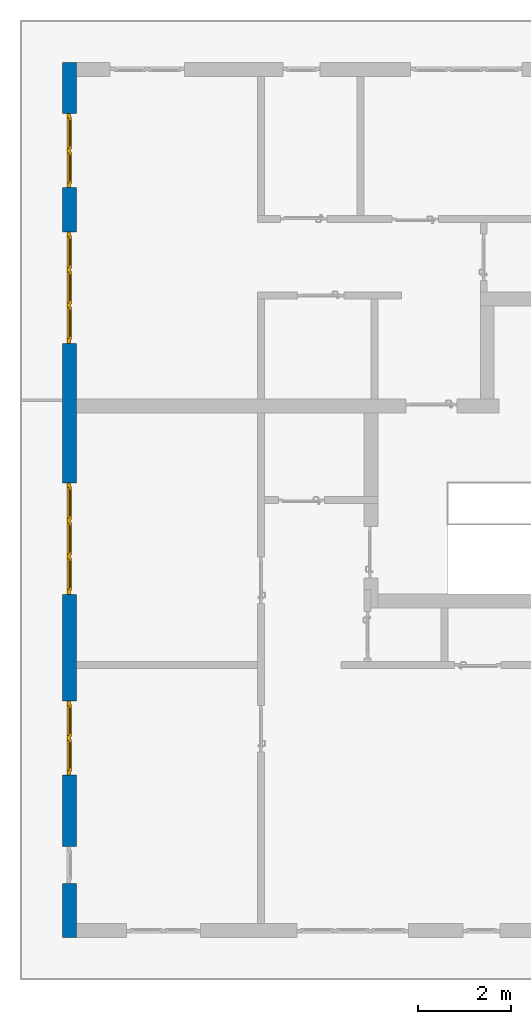
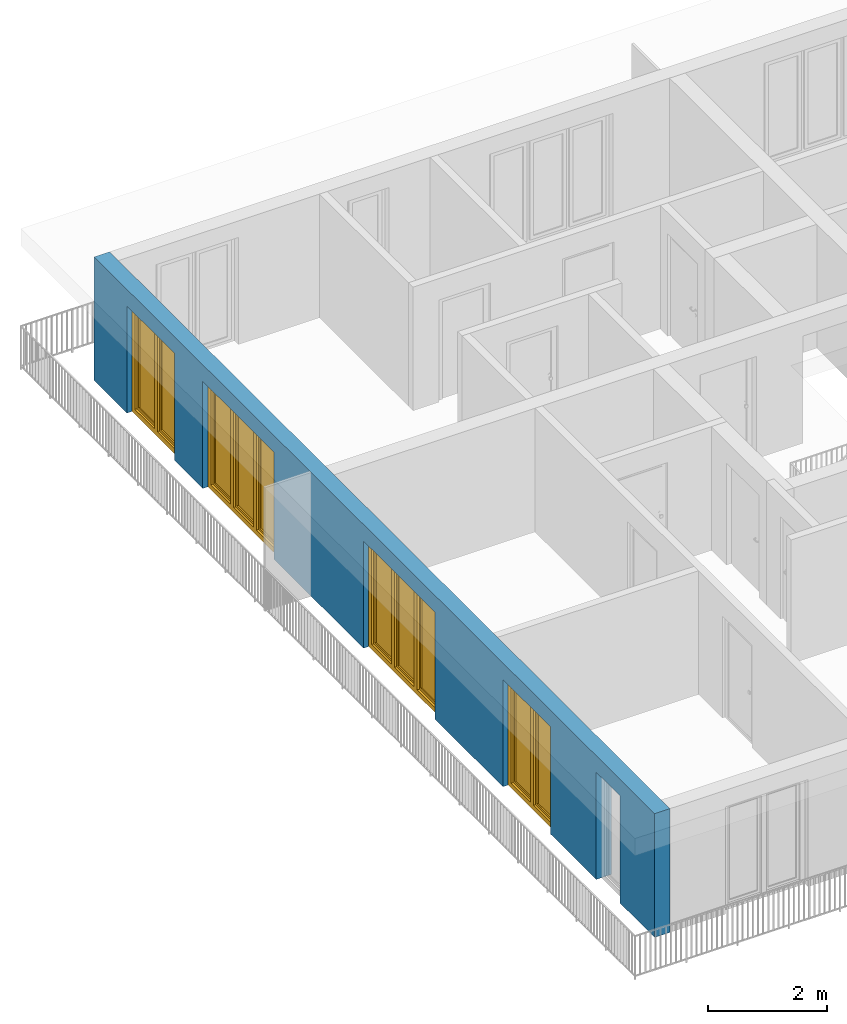
# One storey, part 11 of 54: 4 windows, 1 wall, 5 openings.
"""IFC4 building model written with IfcOpenShell, lengths in metres."""

from ifc_helpers import new_model, entity, si_unit, converted_unit, derived_unit, direction, frame, origin_with_axes, place, context, subcontext, project, spatial, polygons, source, transform, mapped, material, type_object, element, fill, save


model = new_model("IFC4")

# Units and contexts
model_context = context("Model", 3, precision=1e-05, world=origin_with_axes(), true_north=direction((0.0, 1.0)))
body_context = subcontext(model_context, "Body", "Model", "MODEL_VIEW")
ifc_project = project(units=[si_unit("LENGTHUNIT", "METRE"), si_unit("AREAUNIT", "SQUARE_METRE"), si_unit("VOLUMEUNIT", "CUBIC_METRE"), converted_unit("PLANEANGLEUNIT", "DEGREE", entity("IfcPlaneAngleMeasure", 0.0174532925199), si_unit("PLANEANGLEUNIT", "RADIAN"), dimensions=[0, 0, 0, 0, 0, 0, 0]), converted_unit("TIMEUNIT", "Year", entity("IfcTimeMeasure", 31556926.0), si_unit("TIMEUNIT", "SECOND"), dimensions=[0, 0, 1, 0, 0, 0, 0]), si_unit("MASSUNIT", "GRAM", prefix="KILO"), si_unit("THERMODYNAMICTEMPERATUREUNIT", "DEGREE_CELSIUS"), si_unit("LUMINOUSINTENSITYUNIT", "LUMEN"), si_unit("ENERGYUNIT", "JOULE", prefix="MEGA"), derived_unit("THERMALCONDUCTANCEUNIT", [(si_unit("POWERUNIT", "WATT"), 1), (si_unit("LENGTHUNIT", "METRE"), -1), (si_unit("THERMODYNAMICTEMPERATUREUNIT", "KELVIN"), -1)]), derived_unit("SPECIFICHEATCAPACITYUNIT", [(si_unit("ENERGYUNIT", "JOULE"), 1), (si_unit("MASSUNIT", "GRAM", prefix="KILO"), -1), (si_unit("THERMODYNAMICTEMPERATUREUNIT", "KELVIN"), -1)]), derived_unit("MASSDENSITYUNIT", [(si_unit("MASSUNIT", "GRAM", prefix="KILO"), 1), (si_unit("VOLUMEUNIT", "CUBIC_METRE"), -1)])], contexts=[model_context])

# Site, building, storey
site_placement = place(None, origin_with_axes())
site = spatial("IfcSite", under=ifc_project, at=site_placement, CompositionType="ELEMENT")
building_placement = place(site_placement, origin_with_axes())
building = spatial("IfcBuilding", under=site, at=building_placement, CompositionType="ELEMENT")
storey_placement = place(building_placement, frame((0.0, 0.0, 6.29), z_axis=(0.0, 0.0, 1.0), x_axis=(1.0, 0.0, 0.0)))
storey = spatial("IfcBuildingStorey", under=building, at=storey_placement, Name="2. Geschoss", CompositionType="ELEMENT", Elevation=6.29)

# Wall, openings, windows
ifc_material = material()
wall_type = type_object("IfcWallType", Name="300", PredefinedType="NOTDEFINED")
wall_placement = place(storey_placement, frame((-11.7421993804, -9.92881223104, 0.0), z_axis=(0.0, 0.0, 1.0), x_axis=(0.0, 1.0, 0.0)))
wall = element("IfcWall", 1, at=wall_placement, inside=storey, type_object=wall_type, material=ifc_material, Name="Wand-001", PredefinedType="NOTDEFINED", context=body_context, shape_type="Tessellation", body=[
    polygons([(1.16441876325, -0.3, 0.0), (1.16441876325, -0.3, 2.2), (1.96441876325, -0.3, 2.2), (1.96441876325, -0.3, 0.0), (3.5, -0.3, 0.0), (3.5, -0.3, 2.2), (5.1, -0.3, 2.2), (5.1, -0.3, 0.0), (7.3921181063, -0.3, 0.0), (7.3921181063, -0.3, 2.2), (9.7921181063, -0.3, 2.2), (9.7921181063, -0.3, 0.0), (12.8, -0.3, 0.0), (12.8, -0.3, 2.2), (15.2, -0.3, 2.2), (15.2, -0.3, 0.0), (16.15, -0.3, 0.0), (16.15, -0.3, 2.2), (17.75, -0.3, 2.2), (17.75, -0.3, 0.0), (18.85, -0.3, 0.0), (18.85, -0.3, 2.54), (0.0, -0.3, 2.54), (0.0, -0.3, 0.0), (1.16441876325, -0.1, 0.0), (1.16441876325, -0.1, 2.2), (1.96441876325, -0.1, 2.2), (1.96441876325, -0.1, 0.0), (1.96441876325, 0.0, 0.0), (3.5, 0.0, 0.0), (3.5, -0.1, 0.0), (3.5, -0.1, 2.2), (5.1, -0.1, 2.2), (5.1, -0.1, 0.0), (5.1, 0.0, 0.0), (7.3921181063, 0.0, 0.0), (7.3921181063, -0.1, 0.0), (7.3921181063, -0.1, 2.2), (9.7921181063, -0.1, 2.2), (9.7921181063, -0.1, 0.0), (9.7921181063, 0.0, 0.0), (12.8, 0.0, 0.0), (12.8, -0.1, 0.0), (12.8, -0.1, 2.2), (15.2, -0.1, 2.2), (15.2, -0.1, 0.0), (15.2, 0.0, 0.0), (16.15, 0.0, 0.0), (16.15, -0.1, 0.0), (16.15, -0.1, 2.2), (17.75, -0.1, 2.2), (17.75, -0.1, 0.0), (17.75, 0.0, 0.0), (18.85, 0.0, 0.0), (18.85, 0.0, 2.54), (0.0, 0.0, 2.54), (0.0, 0.0, 0.0), (1.16441876325, 0.0, 0.0), (1.16441876325, 0.0, 2.2), (1.96441876325, 0.0, 2.2), (17.75, 0.0, 2.2), (16.15, 0.0, 2.2), (15.2, 0.0, 2.2), (12.8, 0.0, 2.2), (9.7921181063, 0.0, 2.2), (7.3921181063, 0.0, 2.2), (5.1, 0.0, 2.2), (3.5, 0.0, 2.2)], [[[1, 2, 3, 4, 5, 6, 7, 8, 9, 10, 11, 12, 13, 14, 15, 16, 17, 18, 19, 20, 21, 22, 23, 24]], [[2, 1, 25, 26]], [[3, 2, 26, 27]], [[4, 3, 27, 28]], [[4, 28, 29, 30, 31, 5]], [[31, 32, 6, 5]], [[32, 33, 7, 6]], [[33, 34, 8, 7]], [[8, 34, 35, 36, 37, 9]], [[10, 9, 37, 38]], [[11, 10, 38, 39]], [[12, 11, 39, 40]], [[12, 40, 41, 42, 43, 13]], [[43, 44, 14, 13]], [[44, 45, 15, 14]], [[45, 46, 16, 15]], [[16, 46, 47, 48, 49, 17]], [[18, 17, 49, 50]], [[19, 18, 50, 51]], [[20, 19, 51, 52]], [[52, 53, 54, 21, 20]], [[22, 21, 54, 55]], [[22, 55, 56, 23]], [[56, 57, 24, 23]], [[25, 1, 24, 57, 58]], [[26, 25, 58, 59]], [[27, 26, 59, 60]], [[28, 27, 60, 29]], [[30, 29, 60, 59, 58, 57, 56, 55, 54, 53, 61, 62, 48, 47, 63, 64, 42, 41, 65, 66, 36, 35, 67, 68]], [[30, 68, 32, 31]], [[68, 67, 33, 32]], [[67, 35, 34, 33]], [[38, 37, 36, 66]], [[39, 38, 66, 65]], [[40, 39, 65, 41]], [[42, 64, 44, 43]], [[64, 63, 45, 44]], [[63, 47, 46, 45]], [[50, 49, 48, 62]], [[51, 50, 62, 61]], [[52, 51, 61, 53]]], closed=True),
])
opening_1_placement = place(wall_placement, frame((16.95, 0.0, 0.0), z_axis=(0.0, 0.0, 1.0), x_axis=(1.0, 0.0, 0.0)))
opening_1 = element("IfcOpeningElement", 2, at=opening_1_placement, cuts=wall, Name="Fenster-001", context=body_context, identifier="Reference", shape_type="Tessellation", body=[
    polygons([(-0.8, -0.1, 0.0), (-0.8, -0.1, 2.2), (-0.8, 0.000999999999999, 2.2), (-0.8, 0.000999999999999, 0.0), (-0.8, -0.301, 0.0), (-0.8, -0.301, 2.2), (0.8, -0.1, 2.2), (0.8, 0.000999999999999, 2.2), (0.8, -0.301, 2.2), (0.8, 0.000999999999999, 0.0), (0.8, -0.1, 0.0), (0.8, -0.301, 0.0)], [[[1, 2, 3, 4]], [[2, 1, 5, 6]], [[7, 8, 3, 2, 6, 9]], [[8, 10, 4, 3]], [[1, 4, 10, 11, 12, 5]], [[6, 5, 12, 9]], [[7, 11, 10, 8]], [[11, 7, 9, 12]]], closed=True),
])
opening_2_placement = place(wall_placement, frame((14.0, 0.0, 0.0), z_axis=(0.0, 0.0, 1.0), x_axis=(1.0, 0.0, 0.0)))
opening_2 = element("IfcOpeningElement", 3, at=opening_2_placement, cuts=wall, Name="Fenster-002", context=body_context, identifier="Reference", shape_type="Tessellation", body=[
    polygons([(-1.2, -0.1, 0.0), (-1.2, -0.1, 2.2), (-1.2, 0.000999999999999, 2.2), (-1.2, 0.000999999999999, 0.0), (-1.2, -0.301, 0.0), (-1.2, -0.301, 2.2), (1.2, -0.1, 2.2), (1.2, 0.000999999999999, 2.2), (1.2, -0.301, 2.2), (1.2, 0.000999999999999, 0.0), (1.2, -0.1, 0.0), (1.2, -0.301, 0.0)], [[[1, 2, 3, 4]], [[2, 1, 5, 6]], [[7, 8, 3, 2, 6, 9]], [[8, 10, 4, 3]], [[1, 4, 10, 11, 12, 5]], [[6, 5, 12, 9]], [[7, 11, 10, 8]], [[11, 7, 9, 12]]], closed=True),
])
opening_3_placement = place(wall_placement, frame((8.5921181063, 0.0, 0.0), z_axis=(0.0, 0.0, 1.0), x_axis=(1.0, 0.0, 0.0)))
opening_3 = element("IfcOpeningElement", 4, at=opening_3_placement, cuts=wall, Name="Fenster-002", context=body_context, identifier="Reference", shape_type="Tessellation", body=[
    polygons([(-1.2, -0.1, 0.0), (-1.2, -0.1, 2.2), (-1.2, 0.000999999999999, 2.2), (-1.2, 0.000999999999999, 0.0), (-1.2, -0.301, 0.0), (-1.2, -0.301, 2.2), (1.2, -0.1, 2.2), (1.2, 0.000999999999999, 2.2), (1.2, -0.301, 2.2), (1.2, 0.000999999999999, 0.0), (1.2, -0.1, 0.0), (1.2, -0.301, 0.0)], [[[1, 2, 3, 4]], [[2, 1, 5, 6]], [[7, 8, 3, 2, 6, 9]], [[8, 10, 4, 3]], [[1, 4, 10, 11, 12, 5]], [[6, 5, 12, 9]], [[7, 11, 10, 8]], [[11, 7, 9, 12]]], closed=True),
])
opening_4_placement = place(wall_placement, frame((4.3, 0.0, 0.0), z_axis=(0.0, 0.0, 1.0), x_axis=(1.0, 0.0, 0.0)))
opening_4 = element("IfcOpeningElement", 5, at=opening_4_placement, cuts=wall, Name="Fenster-001", context=body_context, identifier="Reference", shape_type="Tessellation", body=[
    polygons([(-0.8, -0.1, 0.0), (-0.8, -0.1, 2.2), (-0.8, 0.000999999999999, 2.2), (-0.8, 0.000999999999999, 0.0), (-0.8, -0.301, 0.0), (-0.8, -0.301, 2.2), (0.8, -0.1, 2.2), (0.8, 0.000999999999999, 2.2), (0.8, -0.301, 2.2), (0.8, 0.000999999999999, 0.0), (0.8, -0.1, 0.0), (0.8, -0.301, 0.0)], [[[1, 2, 3, 4]], [[2, 1, 5, 6]], [[7, 8, 3, 2, 6, 9]], [[8, 10, 4, 3]], [[1, 4, 10, 11, 12, 5]], [[6, 5, 12, 9]], [[7, 11, 10, 8]], [[11, 7, 9, 12]]], closed=True),
])
opening_5_placement = place(wall_placement, frame((1.56441876325, 0.0, 0.0), z_axis=(0.0, 0.0, 1.0), x_axis=(1.0, 0.0, 0.0)))
element("IfcOpeningElement", 6, at=opening_5_placement, cuts=wall, Name="Fenster-003", context=body_context, identifier="Reference", shape_type="Tessellation", body=[
    polygons([(-0.4, -0.1, 0.0), (-0.4, -0.1, 2.2), (-0.4, 0.000999999999999, 2.2), (-0.4, 0.000999999999999, 0.0), (-0.4, -0.301, 0.0), (-0.4, -0.301, 2.2), (0.4, -0.1, 2.2), (0.4, 0.000999999999999, 2.2), (0.4, -0.301, 2.2), (0.4, 0.000999999999999, 0.0), (0.4, -0.1, 0.0), (0.4, -0.301, 0.0)], [[[1, 2, 3, 4]], [[2, 1, 5, 6]], [[7, 8, 3, 2, 6, 9]], [[8, 10, 4, 3]], [[1, 4, 10, 11, 12, 5]], [[6, 5, 12, 9]], [[7, 11, 10, 8]], [[11, 7, 9, 12]]], closed=True),
])
window_type_1 = type_object("IfcWindowType", Name="2-1+1 26", PartitioningType="DOUBLE_PANEL_VERTICAL", PredefinedType="WINDOW")
shared_shape_1 = source(origin_with_axes(), body_context, "Body", "Tessellation", [
    polygons([(0.8, -0.07, 0.0), (0.7, -0.07, 0.1), (0.7, 0.0, 0.1), (0.8, 0.0, 0.0), (0.8, -0.07, 2.2), (0.7, -0.07, 2.1), (0.7, 0.0, 2.1), (0.8, 0.0, 2.2)], [[[1, 2, 3, 4]], [[1, 5, 6, 2]], [[2, 6, 7, 3]], [[4, 3, 7, 8]], [[5, 1, 4, 8]], [[6, 5, 8, 7]]], closed=True),
    polygons([(-0.8, -0.07, 0.0), (-0.8, -0.07, 2.2), (-0.8, 0.0, 2.2), (-0.8, 0.0, 0.0), (-0.7, -0.07, 0.1), (-0.7, -0.07, 2.1), (-0.7, 0.0, 2.1), (-0.7, 0.0, 0.1)], [[[1, 2, 3, 4]], [[1, 5, 6, 2]], [[2, 6, 7, 3]], [[4, 3, 7, 8]], [[5, 1, 4, 8]], [[6, 5, 8, 7]]], closed=True),
    polygons([(0.8, -0.07, 0.0), (-0.8, -0.07, 0.0), (-0.8, 0.0, 0.0), (0.8, 0.0, 0.0), (0.7, -0.07, 0.1), (0.05, -0.07, 0.1), (-0.05, -0.07, 0.1), (-0.7, -0.07, 0.1), (-0.7, 0.0, 0.1), (-0.05, 0.0, 0.1), (0.05, 0.0, 0.1), (0.7, 0.0, 0.1)], [[[1, 2, 3, 4]], [[1, 5, 6, 7, 8, 2]], [[2, 8, 9, 3]], [[4, 3, 9, 10, 11, 12]], [[5, 1, 4, 12]], [[6, 5, 12, 11]], [[7, 6, 11, 10]], [[8, 7, 10, 9]]], closed=True),
    polygons([(0.8, -0.07, 2.2), (0.7, -0.07, 2.1), (0.7, 0.0, 2.1), (0.8, 0.0, 2.2), (-0.8, -0.07, 2.2), (-0.7, -0.07, 2.1), (-0.05, -0.07, 2.1), (0.05, -0.07, 2.1), (0.05, 0.0, 2.1), (-0.05, 0.0, 2.1), (-0.7, 0.0, 2.1), (-0.8, 0.0, 2.2)], [[[1, 2, 3, 4]], [[1, 5, 6, 7, 8, 2]], [[2, 8, 9, 3]], [[4, 3, 9, 10, 11, 12]], [[5, 1, 4, 12]], [[6, 5, 12, 11]], [[7, 6, 11, 10]], [[8, 7, 10, 9]]], closed=True),
    polygons([(0.05, -0.07, 0.1), (-0.05, -0.07, 0.1), (-0.05, 0.0, 0.1), (0.05, 0.0, 0.1), (0.05, -0.07, 2.1), (-0.05, -0.07, 2.1), (-0.05, 0.0, 2.1), (0.05, 0.0, 2.1)], [[[1, 2, 3, 4]], [[1, 5, 6, 2]], [[2, 6, 7, 3]], [[4, 3, 7, 8]], [[5, 1, 4, 8]], [[6, 5, 8, 7]]], closed=True),
    polygons([(0.72, 0.0, 0.08), (0.65, 0.0, 0.15), (0.65, 0.03, 0.15), (0.72, 0.03, 0.08), (0.72, 0.0, 2.12), (0.65, 0.0, 2.05), (0.65, 0.03, 2.05), (0.72, 0.03, 2.12)], [[[1, 2, 3, 4]], [[1, 5, 6, 2]], [[2, 6, 7, 3]], [[4, 3, 7, 8]], [[5, 1, 4, 8]], [[6, 5, 8, 7]]], closed=True),
    polygons([(0.03, 0.0, 0.08), (0.03, 0.03, 0.08), (0.1, 0.03, 0.15), (0.1, 0.0, 0.15), (0.03, 0.0, 2.12), (0.03, 0.03, 2.12), (0.1, 0.03, 2.05), (0.1, 0.0, 2.05)], [[[1, 2, 3, 4]], [[5, 6, 2, 1]], [[2, 6, 7, 3]], [[4, 3, 7, 8]], [[1, 4, 8, 5]], [[8, 7, 6, 5]]], closed=True),
    polygons([(0.72, 0.0, 0.08), (0.03, 0.0, 0.08), (0.03, 0.03, 0.08), (0.72, 0.03, 0.08), (0.65, 0.0, 0.15), (0.1, 0.0, 0.15), (0.1, 0.03, 0.15), (0.65, 0.03, 0.15)], [[[1, 2, 3, 4]], [[1, 5, 6, 2]], [[2, 6, 7, 3]], [[4, 3, 7, 8]], [[5, 1, 4, 8]], [[6, 5, 8, 7]]], closed=True),
    polygons([(0.72, 0.0, 2.12), (0.72, 0.03, 2.12), (0.03, 0.03, 2.12), (0.03, 0.0, 2.12), (0.65, 0.0, 2.05), (0.65, 0.03, 2.05), (0.1, 0.03, 2.05), (0.1, 0.0, 2.05)], [[[1, 2, 3, 4]], [[5, 6, 2, 1]], [[2, 6, 7, 3]], [[4, 3, 7, 8]], [[1, 4, 8, 5]], [[8, 7, 6, 5]]], closed=True),
    polygons([(0.7, -0.03, 0.1), (0.65, -0.03, 0.15), (0.65, 0.0, 0.15), (0.7, 0.0, 0.1), (0.7, -0.03, 2.1), (0.65, -0.03, 2.05), (0.65, 0.0, 2.05), (0.7, 0.0, 2.1)], [[[1, 2, 3, 4]], [[1, 5, 6, 2]], [[2, 6, 7, 3]], [[4, 3, 7, 8]], [[5, 1, 4, 8]], [[6, 5, 8, 7]]], closed=True),
    polygons([(0.05, -0.03, 0.1), (0.05, 0.0, 0.1), (0.1, 0.0, 0.15), (0.1, -0.03, 0.15), (0.05, -0.03, 2.1), (0.05, 0.0, 2.1), (0.1, 0.0, 2.05), (0.1, -0.03, 2.05)], [[[1, 2, 3, 4]], [[5, 6, 2, 1]], [[2, 6, 7, 3]], [[4, 3, 7, 8]], [[1, 4, 8, 5]], [[8, 7, 6, 5]]], closed=True),
    polygons([(0.7, -0.03, 0.1), (0.05, -0.03, 0.1), (0.05, 0.0, 0.1), (0.7, 0.0, 0.1), (0.65, -0.03, 0.15), (0.1, -0.03, 0.15), (0.1, 0.0, 0.15), (0.65, 0.0, 0.15)], [[[1, 2, 3, 4]], [[1, 5, 6, 2]], [[2, 6, 7, 3]], [[4, 3, 7, 8]], [[5, 1, 4, 8]], [[6, 5, 8, 7]]], closed=True),
    polygons([(0.7, -0.03, 2.1), (0.7, 0.0, 2.1), (0.05, 0.0, 2.1), (0.05, -0.03, 2.1), (0.65, -0.03, 2.05), (0.65, 0.0, 2.05), (0.1, 0.0, 2.05), (0.1, -0.03, 2.05)], [[[1, 2, 3, 4]], [[5, 6, 2, 1]], [[2, 6, 7, 3]], [[4, 3, 7, 8]], [[1, 4, 8, 5]], [[8, 7, 6, 5]]], closed=True),
    polygons([(0.65, -0.005, 0.15), (0.1, -0.005, 0.15), (0.1, 0.005, 0.15), (0.65, 0.005, 0.15), (0.65, -0.005, 2.05), (0.1, -0.005, 2.05), (0.1, 0.005, 2.05), (0.65, 0.005, 2.05)], [[[1, 2, 3, 4]], [[1, 5, 6, 2]], [[2, 6, 7, 3]], [[4, 3, 7, 8]], [[5, 1, 4, 8]], [[6, 5, 8, 7]]], closed=True),
    polygons([(-0.03, 0.0, 0.08), (-0.1, 0.0, 0.15), (-0.1, 0.03, 0.15), (-0.03, 0.03, 0.08), (-0.03, 0.0, 2.12), (-0.1, 0.0, 2.05), (-0.1, 0.03, 2.05), (-0.03, 0.03, 2.12)], [[[1, 2, 3, 4]], [[1, 5, 6, 2]], [[2, 6, 7, 3]], [[4, 3, 7, 8]], [[5, 1, 4, 8]], [[6, 5, 8, 7]]], closed=True),
    polygons([(-0.72, 0.0, 0.08), (-0.72, 0.03, 0.08), (-0.65, 0.03, 0.15), (-0.65, 0.0, 0.15), (-0.72, 0.0, 2.12), (-0.72, 0.03, 2.12), (-0.65, 0.03, 2.05), (-0.65, 0.0, 2.05)], [[[1, 2, 3, 4]], [[5, 6, 2, 1]], [[2, 6, 7, 3]], [[4, 3, 7, 8]], [[1, 4, 8, 5]], [[8, 7, 6, 5]]], closed=True),
    polygons([(-0.03, 0.0, 0.08), (-0.72, 0.0, 0.08), (-0.72, 0.03, 0.08), (-0.03, 0.03, 0.08), (-0.1, 0.0, 0.15), (-0.65, 0.0, 0.15), (-0.65, 0.03, 0.15), (-0.1, 0.03, 0.15)], [[[1, 2, 3, 4]], [[1, 5, 6, 2]], [[2, 6, 7, 3]], [[4, 3, 7, 8]], [[5, 1, 4, 8]], [[6, 5, 8, 7]]], closed=True),
    polygons([(-0.03, 0.0, 2.12), (-0.03, 0.03, 2.12), (-0.72, 0.03, 2.12), (-0.72, 0.0, 2.12), (-0.1, 0.0, 2.05), (-0.1, 0.03, 2.05), (-0.65, 0.03, 2.05), (-0.65, 0.0, 2.05)], [[[1, 2, 3, 4]], [[5, 6, 2, 1]], [[2, 6, 7, 3]], [[4, 3, 7, 8]], [[1, 4, 8, 5]], [[8, 7, 6, 5]]], closed=True),
    polygons([(-0.05, -0.03, 0.1), (-0.1, -0.03, 0.15), (-0.1, 0.0, 0.15), (-0.05, 0.0, 0.1), (-0.05, -0.03, 2.1), (-0.1, -0.03, 2.05), (-0.1, 0.0, 2.05), (-0.05, 0.0, 2.1)], [[[1, 2, 3, 4]], [[1, 5, 6, 2]], [[2, 6, 7, 3]], [[4, 3, 7, 8]], [[5, 1, 4, 8]], [[6, 5, 8, 7]]], closed=True),
    polygons([(-0.7, -0.03, 0.1), (-0.7, 0.0, 0.1), (-0.65, 0.0, 0.15), (-0.65, -0.03, 0.15), (-0.7, -0.03, 2.1), (-0.7, 0.0, 2.1), (-0.65, 0.0, 2.05), (-0.65, -0.03, 2.05)], [[[1, 2, 3, 4]], [[5, 6, 2, 1]], [[2, 6, 7, 3]], [[4, 3, 7, 8]], [[1, 4, 8, 5]], [[8, 7, 6, 5]]], closed=True),
    polygons([(-0.05, -0.03, 0.1), (-0.7, -0.03, 0.1), (-0.7, 0.0, 0.1), (-0.05, 0.0, 0.1), (-0.1, -0.03, 0.15), (-0.65, -0.03, 0.15), (-0.65, 0.0, 0.15), (-0.1, 0.0, 0.15)], [[[1, 2, 3, 4]], [[1, 5, 6, 2]], [[2, 6, 7, 3]], [[4, 3, 7, 8]], [[5, 1, 4, 8]], [[6, 5, 8, 7]]], closed=True),
    polygons([(-0.05, -0.03, 2.1), (-0.05, 0.0, 2.1), (-0.7, 0.0, 2.1), (-0.7, -0.03, 2.1), (-0.1, -0.03, 2.05), (-0.1, 0.0, 2.05), (-0.65, 0.0, 2.05), (-0.65, -0.03, 2.05)], [[[1, 2, 3, 4]], [[5, 6, 2, 1]], [[2, 6, 7, 3]], [[4, 3, 7, 8]], [[1, 4, 8, 5]], [[8, 7, 6, 5]]], closed=True),
    polygons([(-0.1, -0.005, 0.15), (-0.65, -0.005, 0.15), (-0.65, 0.005, 0.15), (-0.1, 0.005, 0.15), (-0.1, -0.005, 2.05), (-0.65, -0.005, 2.05), (-0.65, 0.005, 2.05), (-0.1, 0.005, 2.05)], [[[1, 2, 3, 4]], [[1, 5, 6, 2]], [[2, 6, 7, 3]], [[4, 3, 7, 8]], [[5, 1, 4, 8]], [[6, 5, 8, 7]]], closed=True),
])
window_1_placement = place(opening_1_placement, frame((0.8, 0.0, 0.0), z_axis=(0.0, 0.0, 1.0), x_axis=(-1.0, 0.0, 0.0)))
window_1 = element("IfcWindow", 7, at=window_1_placement, inside=storey, type_object=window_type_1, Name="Fenster-001", OverallHeight=2.2, OverallWidth=1.6, PredefinedType="WINDOW", context=body_context, shape_type="MappedRepresentation", body=[
    mapped(shared_shape_1, transform((0.8, 0.17, 0.0))),
])
fill(opening_1, window_1)
window_2_placement = place(opening_4_placement, frame((0.8, 0.0, 0.0), z_axis=(0.0, 0.0, 1.0), x_axis=(-1.0, 0.0, 0.0)))
window_2 = element("IfcWindow", 8, at=window_2_placement, inside=storey, type_object=window_type_1, Name="Fenster-001", OverallHeight=2.2, OverallWidth=1.6, PredefinedType="WINDOW", context=body_context, shape_type="MappedRepresentation", body=[
    mapped(shared_shape_1, transform((0.8, 0.17, 0.0))),
])
fill(opening_4, window_2)
window_type_2 = type_object("IfcWindowType", Name="3-1+1+1 26", PartitioningType="TRIPLE_PANEL_VERTICAL", PredefinedType="WINDOW")
shared_shape_2 = source(origin_with_axes(), body_context, "Body", "Tessellation", [
    polygons([(1.2, -0.07, 0.0), (1.1, -0.07, 0.1), (1.1, 0.0, 0.1), (1.2, 0.0, 0.0), (1.2, -0.07, 2.2), (1.1, -0.07, 2.1), (1.1, 0.0, 2.1), (1.2, 0.0, 2.2)], [[[1, 2, 3, 4]], [[1, 5, 6, 2]], [[2, 6, 7, 3]], [[4, 3, 7, 8]], [[5, 1, 4, 8]], [[6, 5, 8, 7]]], closed=True),
    polygons([(-1.2, -0.07, 0.0), (-1.2, -0.07, 2.2), (-1.2, 0.0, 2.2), (-1.2, 0.0, 0.0), (-1.1, -0.07, 0.1), (-1.1, -0.07, 2.1), (-1.1, 0.0, 2.1), (-1.1, 0.0, 0.1)], [[[1, 2, 3, 4]], [[1, 5, 6, 2]], [[2, 6, 7, 3]], [[4, 3, 7, 8]], [[5, 1, 4, 8]], [[6, 5, 8, 7]]], closed=True),
    polygons([(1.2, -0.07, 0.0), (-1.2, -0.07, 0.0), (-1.2, 0.0, 0.0), (1.2, 0.0, 0.0), (1.1, -0.07, 0.1), (0.433333333333, -0.07, 0.1), (0.333333333333, -0.07, 0.1), (-0.333333333333, -0.07, 0.1), (-0.433333333333, -0.07, 0.1), (-1.1, -0.07, 0.1), (-1.1, 0.0, 0.1), (-0.433333333333, 0.0, 0.1), (-0.333333333333, 0.0, 0.1), (0.333333333333, 0.0, 0.1), (0.433333333333, 0.0, 0.1), (1.1, 0.0, 0.1)], [[[1, 2, 3, 4]], [[1, 5, 6, 7, 8, 9, 10, 2]], [[2, 10, 11, 3]], [[4, 3, 11, 12, 13, 14, 15, 16]], [[5, 1, 4, 16]], [[6, 5, 16, 15]], [[7, 6, 15, 14]], [[8, 7, 14, 13]], [[9, 8, 13, 12]], [[10, 9, 12, 11]]], closed=True),
    polygons([(1.2, -0.07, 2.2), (1.1, -0.07, 2.1), (1.1, 0.0, 2.1), (1.2, 0.0, 2.2), (-1.2, -0.07, 2.2), (-1.1, -0.07, 2.1), (-0.433333333333, -0.07, 2.1), (-0.333333333333, -0.07, 2.1), (0.333333333333, -0.07, 2.1), (0.433333333333, -0.07, 2.1), (0.433333333333, 0.0, 2.1), (0.333333333333, 0.0, 2.1), (-0.333333333333, 0.0, 2.1), (-0.433333333333, 0.0, 2.1), (-1.1, 0.0, 2.1), (-1.2, 0.0, 2.2)], [[[1, 2, 3, 4]], [[1, 5, 6, 7, 8, 9, 10, 2]], [[2, 10, 11, 3]], [[4, 3, 11, 12, 13, 14, 15, 16]], [[5, 1, 4, 16]], [[6, 5, 16, 15]], [[7, 6, 15, 14]], [[8, 7, 14, 13]], [[9, 8, 13, 12]], [[10, 9, 12, 11]]], closed=True),
    polygons([(-0.333333333333, -0.07, 0.1), (-0.433333333333, -0.07, 0.1), (-0.433333333333, 0.0, 0.1), (-0.333333333333, 0.0, 0.1), (-0.333333333333, -0.07, 2.1), (-0.433333333333, -0.07, 2.1), (-0.433333333333, 0.0, 2.1), (-0.333333333333, 0.0, 2.1)], [[[1, 2, 3, 4]], [[1, 5, 6, 2]], [[2, 6, 7, 3]], [[4, 3, 7, 8]], [[5, 1, 4, 8]], [[6, 5, 8, 7]]], closed=True),
    polygons([(0.433333333333, -0.07, 0.1), (0.333333333333, -0.07, 0.1), (0.333333333333, 0.0, 0.1), (0.433333333333, 0.0, 0.1), (0.433333333333, -0.07, 2.1), (0.333333333333, -0.07, 2.1), (0.333333333333, 0.0, 2.1), (0.433333333333, 0.0, 2.1)], [[[1, 2, 3, 4]], [[1, 5, 6, 2]], [[2, 6, 7, 3]], [[4, 3, 7, 8]], [[5, 1, 4, 8]], [[6, 5, 8, 7]]], closed=True),
    polygons([(1.12, 0.0, 0.08), (1.05, 0.0, 0.15), (1.05, 0.03, 0.15), (1.12, 0.03, 0.08), (1.12, 0.0, 2.12), (1.05, 0.0, 2.05), (1.05, 0.03, 2.05), (1.12, 0.03, 2.12)], [[[1, 2, 3, 4]], [[1, 5, 6, 2]], [[2, 6, 7, 3]], [[4, 3, 7, 8]], [[5, 1, 4, 8]], [[6, 5, 8, 7]]], closed=True),
    polygons([(0.413333333333, 0.0, 0.08), (0.413333333333, 0.03, 0.08), (0.483333333333, 0.03, 0.15), (0.483333333333, 0.0, 0.15), (0.413333333333, 0.0, 2.12), (0.413333333333, 0.03, 2.12), (0.483333333333, 0.03, 2.05), (0.483333333333, 0.0, 2.05)], [[[1, 2, 3, 4]], [[5, 6, 2, 1]], [[2, 6, 7, 3]], [[4, 3, 7, 8]], [[1, 4, 8, 5]], [[8, 7, 6, 5]]], closed=True),
    polygons([(1.12, 0.0, 0.08), (0.413333333333, 0.0, 0.08), (0.413333333333, 0.03, 0.08), (1.12, 0.03, 0.08), (1.05, 0.0, 0.15), (0.483333333333, 0.0, 0.15), (0.483333333333, 0.03, 0.15), (1.05, 0.03, 0.15)], [[[1, 2, 3, 4]], [[1, 5, 6, 2]], [[2, 6, 7, 3]], [[4, 3, 7, 8]], [[5, 1, 4, 8]], [[6, 5, 8, 7]]], closed=True),
    polygons([(1.12, 0.0, 2.12), (1.12, 0.03, 2.12), (0.413333333333, 0.03, 2.12), (0.413333333333, 0.0, 2.12), (1.05, 0.0, 2.05), (1.05, 0.03, 2.05), (0.483333333333, 0.03, 2.05), (0.483333333333, 0.0, 2.05)], [[[1, 2, 3, 4]], [[5, 6, 2, 1]], [[2, 6, 7, 3]], [[4, 3, 7, 8]], [[1, 4, 8, 5]], [[8, 7, 6, 5]]], closed=True),
    polygons([(1.1, -0.03, 0.1), (1.05, -0.03, 0.15), (1.05, 0.0, 0.15), (1.1, 0.0, 0.1), (1.1, -0.03, 2.1), (1.05, -0.03, 2.05), (1.05, 0.0, 2.05), (1.1, 0.0, 2.1)], [[[1, 2, 3, 4]], [[1, 5, 6, 2]], [[2, 6, 7, 3]], [[4, 3, 7, 8]], [[5, 1, 4, 8]], [[6, 5, 8, 7]]], closed=True),
    polygons([(0.433333333333, -0.03, 0.1), (0.433333333333, 0.0, 0.1), (0.483333333333, 0.0, 0.15), (0.483333333333, -0.03, 0.15), (0.433333333333, -0.03, 2.1), (0.433333333333, 0.0, 2.1), (0.483333333333, 0.0, 2.05), (0.483333333333, -0.03, 2.05)], [[[1, 2, 3, 4]], [[5, 6, 2, 1]], [[2, 6, 7, 3]], [[4, 3, 7, 8]], [[1, 4, 8, 5]], [[8, 7, 6, 5]]], closed=True),
    polygons([(1.1, -0.03, 0.1), (0.433333333333, -0.03, 0.1), (0.433333333333, 0.0, 0.1), (1.1, 0.0, 0.1), (1.05, -0.03, 0.15), (0.483333333333, -0.03, 0.15), (0.483333333333, 0.0, 0.15), (1.05, 0.0, 0.15)], [[[1, 2, 3, 4]], [[1, 5, 6, 2]], [[2, 6, 7, 3]], [[4, 3, 7, 8]], [[5, 1, 4, 8]], [[6, 5, 8, 7]]], closed=True),
    polygons([(1.1, -0.03, 2.1), (1.1, 0.0, 2.1), (0.433333333333, 0.0, 2.1), (0.433333333333, -0.03, 2.1), (1.05, -0.03, 2.05), (1.05, 0.0, 2.05), (0.483333333333, 0.0, 2.05), (0.483333333333, -0.03, 2.05)], [[[1, 2, 3, 4]], [[5, 6, 2, 1]], [[2, 6, 7, 3]], [[4, 3, 7, 8]], [[1, 4, 8, 5]], [[8, 7, 6, 5]]], closed=True),
    polygons([(1.05, -0.005, 0.15), (0.483333333333, -0.005, 0.15), (0.483333333333, 0.005, 0.15), (1.05, 0.005, 0.15), (1.05, -0.005, 2.05), (0.483333333333, -0.005, 2.05), (0.483333333333, 0.005, 2.05), (1.05, 0.005, 2.05)], [[[1, 2, 3, 4]], [[1, 5, 6, 2]], [[2, 6, 7, 3]], [[4, 3, 7, 8]], [[5, 1, 4, 8]], [[6, 5, 8, 7]]], closed=True),
    polygons([(0.353333333333, 0.0, 0.08), (0.283333333333, 0.0, 0.15), (0.283333333333, 0.03, 0.15), (0.353333333333, 0.03, 0.08), (0.353333333333, 0.0, 2.12), (0.283333333333, 0.0, 2.05), (0.283333333333, 0.03, 2.05), (0.353333333333, 0.03, 2.12)], [[[1, 2, 3, 4]], [[1, 5, 6, 2]], [[2, 6, 7, 3]], [[4, 3, 7, 8]], [[5, 1, 4, 8]], [[6, 5, 8, 7]]], closed=True),
    polygons([(-0.353333333333, 0.0, 0.08), (-0.353333333333, 0.03, 0.08), (-0.283333333333, 0.03, 0.15), (-0.283333333333, 0.0, 0.15), (-0.353333333333, 0.0, 2.12), (-0.353333333333, 0.03, 2.12), (-0.283333333333, 0.03, 2.05), (-0.283333333333, 0.0, 2.05)], [[[1, 2, 3, 4]], [[5, 6, 2, 1]], [[2, 6, 7, 3]], [[4, 3, 7, 8]], [[1, 4, 8, 5]], [[8, 7, 6, 5]]], closed=True),
    polygons([(0.353333333333, 0.0, 0.08), (-0.353333333333, 0.0, 0.08), (-0.353333333333, 0.03, 0.08), (0.353333333333, 0.03, 0.08), (0.283333333333, 0.0, 0.15), (-0.283333333333, 0.0, 0.15), (-0.283333333333, 0.03, 0.15), (0.283333333333, 0.03, 0.15)], [[[1, 2, 3, 4]], [[1, 5, 6, 2]], [[2, 6, 7, 3]], [[4, 3, 7, 8]], [[5, 1, 4, 8]], [[6, 5, 8, 7]]], closed=True),
    polygons([(0.353333333333, 0.0, 2.12), (0.353333333333, 0.03, 2.12), (-0.353333333333, 0.03, 2.12), (-0.353333333333, 0.0, 2.12), (0.283333333333, 0.0, 2.05), (0.283333333333, 0.03, 2.05), (-0.283333333333, 0.03, 2.05), (-0.283333333333, 0.0, 2.05)], [[[1, 2, 3, 4]], [[5, 6, 2, 1]], [[2, 6, 7, 3]], [[4, 3, 7, 8]], [[1, 4, 8, 5]], [[8, 7, 6, 5]]], closed=True),
    polygons([(0.333333333333, -0.03, 0.1), (0.283333333333, -0.03, 0.15), (0.283333333333, 0.0, 0.15), (0.333333333333, 0.0, 0.1), (0.333333333333, -0.03, 2.1), (0.283333333333, -0.03, 2.05), (0.283333333333, 0.0, 2.05), (0.333333333333, 0.0, 2.1)], [[[1, 2, 3, 4]], [[1, 5, 6, 2]], [[2, 6, 7, 3]], [[4, 3, 7, 8]], [[5, 1, 4, 8]], [[6, 5, 8, 7]]], closed=True),
    polygons([(-0.333333333333, -0.03, 0.1), (-0.333333333333, 0.0, 0.1), (-0.283333333333, 0.0, 0.15), (-0.283333333333, -0.03, 0.15), (-0.333333333333, -0.03, 2.1), (-0.333333333333, 0.0, 2.1), (-0.283333333333, 0.0, 2.05), (-0.283333333333, -0.03, 2.05)], [[[1, 2, 3, 4]], [[5, 6, 2, 1]], [[2, 6, 7, 3]], [[4, 3, 7, 8]], [[1, 4, 8, 5]], [[8, 7, 6, 5]]], closed=True),
    polygons([(0.333333333333, -0.03, 0.1), (-0.333333333333, -0.03, 0.1), (-0.333333333333, 0.0, 0.1), (0.333333333333, 0.0, 0.1), (0.283333333333, -0.03, 0.15), (-0.283333333333, -0.03, 0.15), (-0.283333333333, 0.0, 0.15), (0.283333333333, 0.0, 0.15)], [[[1, 2, 3, 4]], [[1, 5, 6, 2]], [[2, 6, 7, 3]], [[4, 3, 7, 8]], [[5, 1, 4, 8]], [[6, 5, 8, 7]]], closed=True),
    polygons([(0.333333333333, -0.03, 2.1), (0.333333333333, 0.0, 2.1), (-0.333333333333, 0.0, 2.1), (-0.333333333333, -0.03, 2.1), (0.283333333333, -0.03, 2.05), (0.283333333333, 0.0, 2.05), (-0.283333333333, 0.0, 2.05), (-0.283333333333, -0.03, 2.05)], [[[1, 2, 3, 4]], [[5, 6, 2, 1]], [[2, 6, 7, 3]], [[4, 3, 7, 8]], [[1, 4, 8, 5]], [[8, 7, 6, 5]]], closed=True),
    polygons([(0.283333333333, -0.005, 0.15), (-0.283333333333, -0.005, 0.15), (-0.283333333333, 0.005, 0.15), (0.283333333333, 0.005, 0.15), (0.283333333333, -0.005, 2.05), (-0.283333333333, -0.005, 2.05), (-0.283333333333, 0.005, 2.05), (0.283333333333, 0.005, 2.05)], [[[1, 2, 3, 4]], [[1, 5, 6, 2]], [[2, 6, 7, 3]], [[4, 3, 7, 8]], [[5, 1, 4, 8]], [[6, 5, 8, 7]]], closed=True),
    polygons([(-0.413333333333, 0.0, 0.08), (-0.483333333333, 0.0, 0.15), (-0.483333333333, 0.03, 0.15), (-0.413333333333, 0.03, 0.08), (-0.413333333333, 0.0, 2.12), (-0.483333333333, 0.0, 2.05), (-0.483333333333, 0.03, 2.05), (-0.413333333333, 0.03, 2.12)], [[[1, 2, 3, 4]], [[1, 5, 6, 2]], [[2, 6, 7, 3]], [[4, 3, 7, 8]], [[5, 1, 4, 8]], [[6, 5, 8, 7]]], closed=True),
    polygons([(-1.12, 0.0, 0.08), (-1.12, 0.03, 0.08), (-1.05, 0.03, 0.15), (-1.05, 0.0, 0.15), (-1.12, 0.0, 2.12), (-1.12, 0.03, 2.12), (-1.05, 0.03, 2.05), (-1.05, 0.0, 2.05)], [[[1, 2, 3, 4]], [[5, 6, 2, 1]], [[2, 6, 7, 3]], [[4, 3, 7, 8]], [[1, 4, 8, 5]], [[8, 7, 6, 5]]], closed=True),
    polygons([(-0.413333333333, 0.0, 0.08), (-1.12, 0.0, 0.08), (-1.12, 0.03, 0.08), (-0.413333333333, 0.03, 0.08), (-0.483333333333, 0.0, 0.15), (-1.05, 0.0, 0.15), (-1.05, 0.03, 0.15), (-0.483333333333, 0.03, 0.15)], [[[1, 2, 3, 4]], [[1, 5, 6, 2]], [[2, 6, 7, 3]], [[4, 3, 7, 8]], [[5, 1, 4, 8]], [[6, 5, 8, 7]]], closed=True),
    polygons([(-0.413333333333, 0.0, 2.12), (-0.413333333333, 0.03, 2.12), (-1.12, 0.03, 2.12), (-1.12, 0.0, 2.12), (-0.483333333333, 0.0, 2.05), (-0.483333333333, 0.03, 2.05), (-1.05, 0.03, 2.05), (-1.05, 0.0, 2.05)], [[[1, 2, 3, 4]], [[5, 6, 2, 1]], [[2, 6, 7, 3]], [[4, 3, 7, 8]], [[1, 4, 8, 5]], [[8, 7, 6, 5]]], closed=True),
    polygons([(-0.433333333333, -0.03, 0.1), (-0.483333333333, -0.03, 0.15), (-0.483333333333, 0.0, 0.15), (-0.433333333333, 0.0, 0.1), (-0.433333333333, -0.03, 2.1), (-0.483333333333, -0.03, 2.05), (-0.483333333333, 0.0, 2.05), (-0.433333333333, 0.0, 2.1)], [[[1, 2, 3, 4]], [[1, 5, 6, 2]], [[2, 6, 7, 3]], [[4, 3, 7, 8]], [[5, 1, 4, 8]], [[6, 5, 8, 7]]], closed=True),
    polygons([(-1.1, -0.03, 0.1), (-1.1, 0.0, 0.1), (-1.05, 0.0, 0.15), (-1.05, -0.03, 0.15), (-1.1, -0.03, 2.1), (-1.1, 0.0, 2.1), (-1.05, 0.0, 2.05), (-1.05, -0.03, 2.05)], [[[1, 2, 3, 4]], [[5, 6, 2, 1]], [[2, 6, 7, 3]], [[4, 3, 7, 8]], [[1, 4, 8, 5]], [[8, 7, 6, 5]]], closed=True),
    polygons([(-0.433333333333, -0.03, 0.1), (-1.1, -0.03, 0.1), (-1.1, 0.0, 0.1), (-0.433333333333, 0.0, 0.1), (-0.483333333333, -0.03, 0.15), (-1.05, -0.03, 0.15), (-1.05, 0.0, 0.15), (-0.483333333333, 0.0, 0.15)], [[[1, 2, 3, 4]], [[1, 5, 6, 2]], [[2, 6, 7, 3]], [[4, 3, 7, 8]], [[5, 1, 4, 8]], [[6, 5, 8, 7]]], closed=True),
    polygons([(-0.433333333333, -0.03, 2.1), (-0.433333333333, 0.0, 2.1), (-1.1, 0.0, 2.1), (-1.1, -0.03, 2.1), (-0.483333333333, -0.03, 2.05), (-0.483333333333, 0.0, 2.05), (-1.05, 0.0, 2.05), (-1.05, -0.03, 2.05)], [[[1, 2, 3, 4]], [[5, 6, 2, 1]], [[2, 6, 7, 3]], [[4, 3, 7, 8]], [[1, 4, 8, 5]], [[8, 7, 6, 5]]], closed=True),
    polygons([(-0.483333333333, -0.005, 0.15), (-1.05, -0.005, 0.15), (-1.05, 0.005, 0.15), (-0.483333333333, 0.005, 0.15), (-0.483333333333, -0.005, 2.05), (-1.05, -0.005, 2.05), (-1.05, 0.005, 2.05), (-0.483333333333, 0.005, 2.05)], [[[1, 2, 3, 4]], [[1, 5, 6, 2]], [[2, 6, 7, 3]], [[4, 3, 7, 8]], [[5, 1, 4, 8]], [[6, 5, 8, 7]]], closed=True),
])
window_3_placement = place(opening_2_placement, frame((1.2, 0.0, 0.0), z_axis=(0.0, 0.0, 1.0), x_axis=(-1.0, 0.0, 0.0)))
window_3 = element("IfcWindow", 9, at=window_3_placement, inside=storey, type_object=window_type_2, Name="Fenster-002", OverallHeight=2.2, OverallWidth=2.4, PredefinedType="WINDOW", context=body_context, shape_type="MappedRepresentation", body=[
    mapped(shared_shape_2, transform((1.2, 0.17, 0.0))),
])
fill(opening_2, window_3)
window_4_placement = place(opening_3_placement, frame((1.2, 0.0, 0.0), z_axis=(0.0, 0.0, 1.0), x_axis=(-1.0, 0.0, 0.0)))
window_4 = element("IfcWindow", 10, at=window_4_placement, inside=storey, type_object=window_type_2, Name="Fenster-002", OverallHeight=2.2, OverallWidth=2.4, PredefinedType="WINDOW", context=body_context, shape_type="MappedRepresentation", body=[
    mapped(shared_shape_2, transform((1.2, 0.17, 0.0))),
])
fill(opening_3, window_4)

save(model, "model.ifc")
